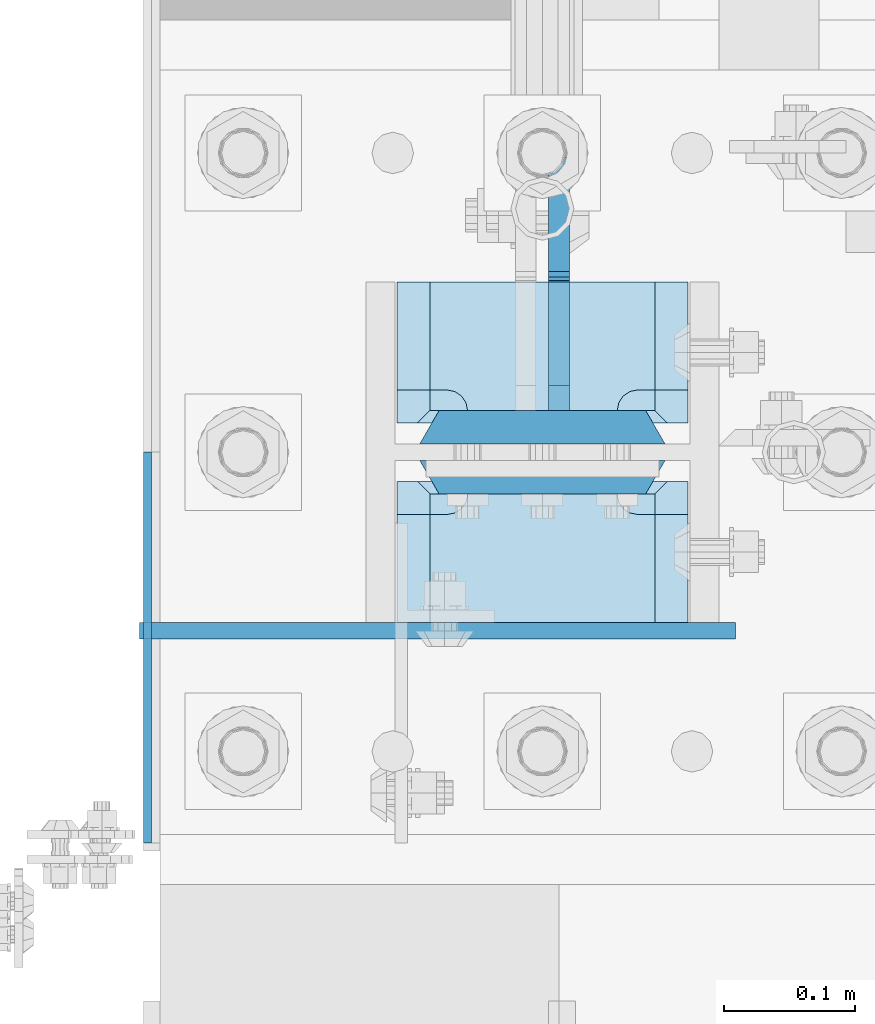
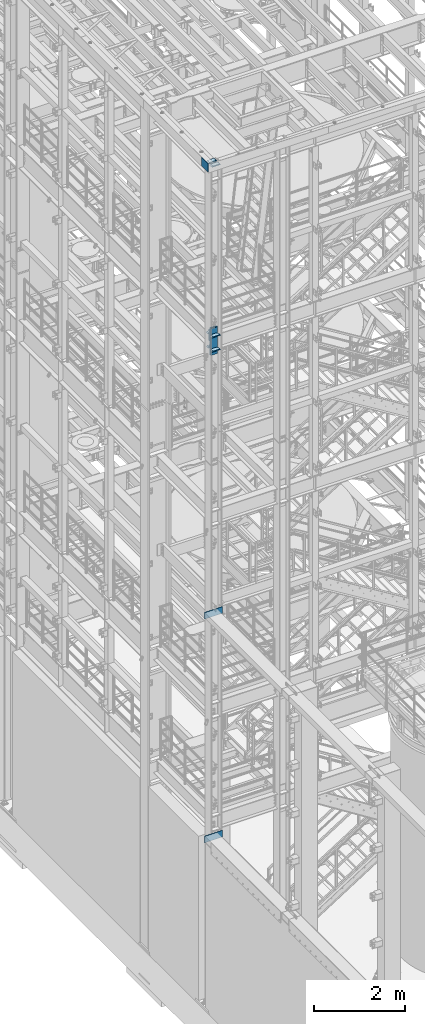
# One storey, part 1420 of 1876: 12 plates, 4 elements without a shape of their own.
"""IFC2X3 building model written with IfcOpenShell, lengths in millimetres."""

from ifc_helpers import new_model, si_unit, frame, origin_with_axes, place, context, subcontext, project, spatial, faceted_brep, material, type_object, element, aggregate, save


model = new_model("IFC2X3")

# Units and contexts
model_context = context("Model", 3, precision=1e-05, world=origin_with_axes())
body_context = subcontext(model_context, "Body", "Model", "MODEL_VIEW")
ifc_project = project(units=[si_unit("LENGTHUNIT", "METRE", prefix="MILLI"), si_unit("AREAUNIT", "SQUARE_METRE"), si_unit("VOLUMEUNIT", "CUBIC_METRE"), si_unit("MASSUNIT", "GRAM", prefix="KILO"), si_unit("TIMEUNIT", "SECOND"), si_unit("PLANEANGLEUNIT", "RADIAN"), si_unit("SOLIDANGLEUNIT", "STERADIAN"), si_unit("THERMODYNAMICTEMPERATUREUNIT", "DEGREE_CELSIUS"), si_unit("LUMINOUSINTENSITYUNIT", "LUMEN")], contexts=[model_context])

# Site, building, storey
site_placement = place(None, origin_with_axes())
site = spatial("IfcSite", under=ifc_project, at=site_placement, CompositionType="ELEMENT")
building_placement = place(site_placement, origin_with_axes())
building = spatial("IfcBuilding", under=site, at=building_placement, Name="Undefined", CompositionType="ELEMENT")
storey_placement = place(building_placement, origin_with_axes())
storey = spatial("IfcBuildingStorey", under=building, at=storey_placement, Name="Undefined", CompositionType="ELEMENT", Elevation=0.0)

# Assembly, plate
assembly_1_placement = place(storey_placement, origin_with_axes())
assembly_1 = element("IfcElementAssembly", 1, at=assembly_1_placement, inside=storey, Name="BEAM", AssemblyPlace="NOTDEFINED", PredefinedType="RIGID_FRAME")
ifc_material_1 = material(Name="STEEL/A36")
plate_type_1 = type_object("IfcPlateType", PredefinedType="NOTDEFINED")
plate_1_placement = place(assembly_1_placement, frame((-307.975000000001, -7248.525, 10680.7), z_axis=(0.0, 0.0, -1.0), x_axis=(1.0, 0.0, 0.0)))
plate_1 = element("IfcPlate", 2, at=plate_1_placement, type_object=plate_type_1, material=ifc_material_1, Name="PLATE", context=body_context, shape_type="Brep", body=[
    faceted_brep([(0.0, -6.35000000000036, 0.0), (1.70530256582424e-13, -6.35000000000036, 177.799987792969), (1.70530256582424e-13, 6.35000000000036, 177.799987792969), (0.0, 6.35000000000036, 0.0), (455.612487792969, -6.35000000000036, 177.799987792969), (455.612487792969, 6.35000000000036, 177.799987792969), (455.612487792969, -6.35000000000036, 0.0), (455.612487792969, 6.35000000000036, 0.0)], [[[0, 1, 2, 3]], [[1, 4, 5, 2]], [[4, 6, 7, 5]], [[6, 0, 3, 7]], [[5, 7, 3, 2]], [[6, 4, 1, 0]]]),
])
aggregate(assembly_1, [plate_1])

assembly_2_placement = place(storey_placement, origin_with_axes())
assembly_2 = element("IfcElementAssembly", 3, at=assembly_2_placement, inside=storey, Name="BEAM", AssemblyPlace="NOTDEFINED", PredefinedType="RIGID_FRAME")
plate_2_placement = place(assembly_2_placement, frame((-307.975, -7248.525, 4686.3), z_axis=(0.0, 0.0, -1.0), x_axis=(1.0, 0.0, 0.0)))
plate_2 = element("IfcPlate", 4, at=plate_2_placement, type_object=plate_type_1, material=ifc_material_1, Name="PLATE", context=body_context, shape_type="Brep", body=[
    faceted_brep([(0.0, -6.35000000000036, 0.0), (1.70530256582424e-13, -6.35000000000036, 177.799987792969), (1.70530256582424e-13, 6.35000000000036, 177.799987792969), (0.0, 6.35000000000036, 0.0), (455.612487792969, -6.35000000000036, 177.799987792969), (455.612487792969, 6.35000000000036, 177.799987792969), (455.612487792969, -6.35000000000036, 0.0), (455.612487792969, 6.35000000000036, 0.0)], [[[0, 1, 2, 3]], [[1, 4, 5, 2]], [[4, 6, 7, 5]], [[6, 0, 3, 7]], [[5, 7, 3, 2]], [[6, 4, 1, 0]]]),
])
aggregate(assembly_2, [plate_2])

# Assembly, plates
assembly_3_placement = place(storey_placement, origin_with_axes())
assembly_3 = element("IfcElementAssembly", 5, at=assembly_3_placement, inside=storey, Name="COLUMN", AssemblyPlace="NOTDEFINED", PredefinedType="RIGID_FRAME")
ifc_material_2 = material(Name="STEEL/A572-50")
plate_type_2 = type_object("IfcPlateType", PredefinedType="NOTDEFINED")
plate_3_placement = place(assembly_3_placement, frame((111.125, -7143.75, 17586.325012207), z_axis=(-1.0, 0.0, 0.0), x_axis=(0.0, -1.0, 0.0)))
plate_3 = element("IfcPlate", 6, at=plate_3_placement, type_object=plate_type_2, material=ifc_material_2, Name="PLATE", context=body_context, shape_type="Brep", body=[
    faceted_brep([(98.4250030517578, -12.7000000000007, 222.25), (98.4250030517578, 12.7000000000007, 197.150000002177), (15.875, 12.7000000000007, 197.150000002177), (15.875, -12.7000000000007, 222.25), (14.6665875786157, -12.7000000000007, 178.074902037082), (15.875, -12.7000000000007, 184.150001525879), (15.875, 12.7000000000007, 184.150001525879), (14.6665875786157, 12.7000000000007, 178.074902037082), (11.2253201513358, -12.7000000000007, 172.924681374541), (11.2253201513358, 12.7000000000007, 172.924681374541), (6.07509948879488, -12.7000000000007, 169.483413947261), (6.07509948879488, 12.7000000000007, 169.483413947261), (0.0, -12.7000000000007, 168.275001525879), (0.0, 12.7000000000007, 168.275001525879), (0.0, -12.7000000000007, 53.9749984741211), (0.0, 12.7000000000007, 53.9749984741211), (6.07509948879579, -12.7000000000007, 52.7665860527377), (6.07509948879579, 12.7000000000007, 52.7665860527377), (11.2253201513367, -12.7000000000007, 49.3253186254576), (11.2253201513367, 12.7000000000007, 49.3253186254576), (14.6665875786166, -12.7000000000007, 44.1750979629169), (14.6665875786166, 12.7000000000007, 44.1750979629169), (15.875, -12.7000000000007, 38.0999984741211), (15.875, 12.7000000000007, 38.0999984741211), (15.875, 12.7000000000007, 25.0999999978233), (15.875, -12.7000000000007, 0.0), (98.4250030517578, 12.7000000000007, 25.0999999978233), (98.4250030517578, -12.7000000000007, 0.0)], [[[0, 1, 2, 3]], [[4, 5, 6, 7]], [[8, 4, 7, 9]], [[10, 8, 9, 11]], [[12, 10, 11, 13]], [[14, 12, 13, 15]], [[16, 14, 15, 17]], [[18, 16, 17, 19]], [[20, 18, 19, 21]], [[22, 20, 21, 23]], [[22, 23, 24, 25]], [[26, 27, 25, 24]], [[5, 4, 8, 10, 12, 14, 16, 18, 20, 22, 25, 27, 0, 3]], [[6, 5, 3, 2]], [[26, 24, 23, 21, 19, 17, 15, 13, 11, 9, 7, 6, 2, 1]], [[27, 26, 1, 0]]]),
])
plate_4_placement = place(assembly_3_placement, frame((111.125, -7143.75, 17970.5), z_axis=(-1.0, 0.0, 0.0), x_axis=(0.0, -1.0, 0.0)))
plate_4 = element("IfcPlate", 7, at=plate_4_placement, type_object=plate_type_2, material=ifc_material_2, Name="PLATE", context=body_context, shape_type="Brep", body=[
    faceted_brep([(98.4250030517578, -12.7000000000007, 222.25), (98.4250030517578, 12.7000000000007, 197.150000002177), (15.875, 12.7000000000007, 197.150000002177), (15.875, -12.7000000000007, 222.25), (14.6665875786157, -12.7000000000007, 178.074902037082), (15.875, -12.7000000000007, 184.150001525879), (15.875, 12.7000000000007, 184.150001525879), (14.6665875786157, 12.7000000000007, 178.074902037082), (11.2253201513358, -12.7000000000007, 172.924681374541), (11.2253201513358, 12.7000000000007, 172.924681374541), (6.07509948879488, -12.7000000000007, 169.483413947261), (6.07509948879488, 12.7000000000007, 169.483413947261), (0.0, -12.7000000000007, 168.275001525879), (0.0, 12.7000000000007, 168.275001525879), (0.0, -12.7000000000007, 53.9749984741211), (0.0, 12.7000000000007, 53.9749984741211), (6.07509948879579, -12.7000000000007, 52.7665860527377), (6.07509948879579, 12.7000000000007, 52.7665860527377), (11.2253201513367, -12.7000000000007, 49.3253186254576), (11.2253201513367, 12.7000000000007, 49.3253186254576), (14.6665875786166, -12.7000000000007, 44.1750979629169), (14.6665875786166, 12.7000000000007, 44.1750979629169), (15.875, -12.7000000000007, 38.0999984741211), (15.875, 12.7000000000007, 38.0999984741211), (15.875, 12.7000000000007, 25.0999999978233), (15.875, -12.7000000000007, 0.0), (98.4250030517578, 12.7000000000007, 25.0999999978233), (98.4250030517578, -12.7000000000007, 0.0)], [[[0, 1, 2, 3]], [[4, 5, 6, 7]], [[8, 4, 7, 9]], [[10, 8, 9, 11]], [[12, 10, 11, 13]], [[14, 12, 13, 15]], [[16, 14, 15, 17]], [[18, 16, 17, 19]], [[20, 18, 19, 21]], [[22, 20, 21, 23]], [[22, 23, 24, 25]], [[26, 27, 25, 24]], [[5, 4, 8, 10, 12, 14, 16, 18, 20, 22, 25, 27, 0, 3]], [[6, 5, 3, 2]], [[26, 24, 23, 21, 19, 17, 15, 13, 11, 9, 7, 6, 2, 1]], [[27, 26, 1, 0]]]),
])
plate_5_placement = place(assembly_3_placement, frame((111.125, -6981.825, 17586.325012207), z_axis=(-1.0, 0.0, 0.0), x_axis=(0.0, -1.0, 0.0)))
plate_5 = element("IfcPlate", 8, at=plate_5_placement, type_object=plate_type_2, material=ifc_material_2, Name="PLATE", context=body_context, shape_type="Brep", body=[
    faceted_brep([(82.5500030517578, -12.7000000000007, 222.25), (82.5500030517578, 12.7000000000007, 197.150000002177), (0.0, 12.7000000000007, 197.150000002177), (0.0, -12.7000000000007, 222.25), (82.5500030517578, 12.7000000000007, 25.0999999978233), (82.5500030517578, -12.7000000000007, 0.0), (0.0, -12.6999999999998, 0.0), (0.0, 12.7000000000007, 25.0999999978233), (82.5500030517578, 12.7000000000007, 38.0999984741211), (82.5500030517578, -12.7000000000007, 38.0999984741211), (83.7584154731412, -12.7000000000007, 44.1750979629169), (83.7584154731412, 12.7000000000007, 44.1750979629169), (87.1996829004211, -12.7000000000007, 49.3253186254576), (87.1996829004211, 12.7000000000007, 49.3253186254576), (92.349903562962, -12.7000000000007, 52.7665860527377), (92.349903562962, 12.7000000000007, 52.7665860527377), (98.4250030517578, -12.7000000000007, 53.9749984741211), (98.4250030517578, 12.7000000000007, 53.9749984741211), (98.4250030517578, -12.7000000000007, 168.275001525879), (98.4250030517578, 12.7000000000007, 168.275001525879), (92.349903562962, -12.7000000000007, 169.483413947262), (92.349903562962, 12.7000000000007, 169.483413947262), (87.1996829004211, -12.7000000000007, 172.924681374543), (87.1996829004211, 12.7000000000007, 172.924681374543), (83.7584154731412, -12.7000000000007, 178.074902037083), (83.7584154731412, 12.7000000000007, 178.074902037083), (82.5500030517578, -12.7000000000007, 184.150001525879), (82.5500030517578, 12.7000000000007, 184.150001525879)], [[[0, 1, 2, 3]], [[4, 5, 6, 7]], [[8, 9, 5, 4]], [[10, 9, 8, 11]], [[12, 10, 11, 13]], [[14, 12, 13, 15]], [[16, 14, 15, 17]], [[18, 16, 17, 19]], [[20, 18, 19, 21]], [[22, 20, 21, 23]], [[24, 22, 23, 25]], [[26, 24, 25, 27]], [[6, 5, 9, 10, 12, 14, 16, 18, 20, 22, 24, 26, 0, 3]], [[7, 6, 3, 2]], [[27, 25, 23, 21, 19, 17, 15, 13, 11, 8, 4, 7, 2, 1]], [[26, 27, 1, 0]]]),
])
plate_6_placement = place(assembly_3_placement, frame((111.125, -6981.825, 17970.5), z_axis=(-1.0, 0.0, 0.0), x_axis=(0.0, -1.0, 0.0)))
plate_6 = element("IfcPlate", 9, at=plate_6_placement, type_object=plate_type_2, material=ifc_material_2, Name="PLATE", context=body_context, shape_type="Brep", body=[
    faceted_brep([(82.5500030517578, -12.7000000000007, 222.25), (82.5500030517578, 12.7000000000007, 197.150000002177), (0.0, 12.7000000000007, 197.150000002177), (0.0, -12.7000000000007, 222.25), (82.5500030517578, 12.7000000000007, 25.0999999978233), (82.5500030517578, -12.7000000000007, 0.0), (0.0, -12.6999999999998, 0.0), (0.0, 12.7000000000007, 25.0999999978233), (82.5500030517578, 12.7000000000007, 38.0999984741211), (82.5500030517578, -12.7000000000007, 38.0999984741211), (83.7584154731412, -12.7000000000007, 44.1750979629169), (83.7584154731412, 12.7000000000007, 44.1750979629169), (87.1996829004211, -12.7000000000007, 49.3253186254576), (87.1996829004211, 12.7000000000007, 49.3253186254576), (92.349903562962, -12.7000000000007, 52.7665860527377), (92.349903562962, 12.7000000000007, 52.7665860527377), (98.4250030517578, -12.7000000000007, 53.9749984741211), (98.4250030517578, 12.7000000000007, 53.9749984741211), (98.4250030517578, -12.7000000000007, 168.275001525879), (98.4250030517578, 12.7000000000007, 168.275001525879), (92.349903562962, -12.7000000000007, 169.483413947262), (92.349903562962, 12.7000000000007, 169.483413947262), (87.1996829004211, -12.7000000000007, 172.924681374543), (87.1996829004211, 12.7000000000007, 172.924681374543), (83.7584154731412, -12.7000000000007, 178.074902037083), (83.7584154731412, 12.7000000000007, 178.074902037083), (82.5500030517578, -12.7000000000007, 184.150001525879), (82.5500030517578, 12.7000000000007, 184.150001525879)], [[[0, 1, 2, 3]], [[4, 5, 6, 7]], [[8, 9, 5, 4]], [[10, 9, 8, 11]], [[12, 10, 11, 13]], [[14, 12, 13, 15]], [[16, 14, 15, 17]], [[18, 16, 17, 19]], [[20, 18, 19, 21]], [[22, 20, 21, 23]], [[24, 22, 23, 25]], [[26, 24, 25, 27]], [[6, 5, 9, 10, 12, 14, 16, 18, 20, 22, 24, 26, 0, 3]], [[7, 6, 3, 2]], [[27, 25, 23, 21, 19, 17, 15, 13, 11, 8, 4, 7, 2, 1]], [[26, 27, 1, 0]]]),
])
ifc_material_3 = material(Name="STEEL/A572-GR.50")
plate_type_3 = type_object("IfcPlateType", PredefinedType="NOTDEFINED")
plate_7_placement = place(assembly_3_placement, frame((-93.6625, -7131.05, 18135.6), z_axis=(1.0, 0.0, 0.0), x_axis=(0.0, 0.0, -1.0)))
plate_7 = element("IfcPlate", 10, at=plate_7_placement, type_object=plate_type_3, material=ifc_material_3, Name="PLATE", context=body_context, shape_type="Brep", body=[
    faceted_brep([(0.0, -12.6999999999998, 172.660303166218), (714.375, -12.6999999999998, 172.660303166232), (714.375, 12.6999999999998, 187.324996948242), (0.0, 12.6999999999998, 187.324996948242), (714.375, -12.6999999999998, 14.6646968337647), (714.375, 12.6999999999998, 0.0), (0.0, 12.6999999999998, 0.0), (0.0, -12.6999999999998, 14.6646968337648)], [[[0, 1, 2, 3]], [[2, 1, 4, 5]], [[3, 2, 5, 6]], [[0, 3, 6, 7]], [[1, 0, 7, 4]], [[6, 5, 4, 7]]]),
])
plate_8_placement = place(assembly_3_placement, frame((-93.6625, -7092.95, 18135.6), z_axis=(1.0, 0.0, 0.0), x_axis=(0.0, 0.0, -1.0)))
plate_8 = element("IfcPlate", 11, at=plate_8_placement, type_object=plate_type_3, material=ifc_material_3, Name="PLATE", context=body_context, shape_type="Brep", body=[
    faceted_brep([(0.0, 12.6999999999998, 172.66030316161), (0.0, -12.6999999999998, 187.324996948242), (714.375, -12.6999999999998, 187.324996948242), (714.375, 12.6999999999998, 172.660303161603), (714.375, 12.6999999999998, 14.6646968384017), (0.0, 12.6999999999998, 14.6646968383725), (0.0, -12.6999999999998, 0.0), (714.375, -12.6999999999998, 0.0)], [[[0, 1, 2, 3]], [[0, 3, 4, 5]], [[1, 0, 5, 6]], [[2, 1, 6, 7]], [[3, 2, 7, 4]], [[6, 5, 4, 7]]]),
])
plate_type_4 = type_object("IfcPlateType", PredefinedType="NOTDEFINED")
plate_9_placement = place(assembly_3_placement, frame((111.124999999997, -7118.35, 22542.5), z_axis=(-1.0, 0.0, 0.0), x_axis=(0.0, -1.0, 0.0)))
plate_9 = element("IfcPlate", 12, at=plate_9_placement, type_object=plate_type_4, material=ifc_material_2, Name="PLATE", context=body_context, shape_type="Brep", body=[
    faceted_brep([(123.824996948242, -12.5499999989115, 222.40000000109), (123.824996948242, 12.7000000000007, 197.15000000218), (25.4000000000024, 12.7000000000007, 197.15000000218), (15.875, 3.17499999999563, 206.675000002184), (15.875, -12.7000000000007, 222.25), (14.6665875786157, -12.7000000000007, 178.074902037082), (15.875, -12.7000000000007, 184.150001525879), (15.875, 3.17499999999563, 184.150001525879), (14.6665875786157, 1.96658757861223, 178.074902037082), (11.2253201513358, -12.7000000000007, 172.924681374541), (11.2253201513358, -1.47467984866671, 172.924681374541), (6.07509948879488, -12.7000000000007, 169.483413947261), (6.07509948879488, -6.62490051120767, 169.483413947261), (0.0, -12.7000000000007, 168.275001525879), (6.07509948879579, -12.7000000000007, 52.7665860527377), (0.0, -12.7000000000007, 53.9749984741211), (6.07509948879579, -6.62490051120767, 52.7665860527377), (11.2253201513367, -12.7000000000007, 49.3253186254576), (11.2253201513367, -1.47467984866671, 49.3253186254576), (14.6665875786166, -12.7000000000007, 44.1750979629169), (14.6665875786166, 1.96658757861223, 44.1750979629169), (15.875, -12.7000000000007, 38.0999984741211), (15.875, 3.17499999999563, 38.0999984741211), (15.875, 3.17499999999563, 15.6499999983591), (15.875, -12.7000000000007, 0.0), (123.824996948242, 12.7000000000007, 25.1749999983624), (123.824996948242, -12.7000000000007, 0.0), (25.4000000000024, 12.7000000000007, 25.1749999983624)], [[[0, 1, 2, 3, 4]], [[5, 6, 7, 8]], [[9, 5, 8, 10]], [[11, 9, 10, 12]], [[11, 12, 13]], [[14, 15, 16]], [[17, 14, 16, 18]], [[19, 17, 18, 20]], [[21, 19, 20, 22]], [[21, 22, 23, 24]], [[25, 26, 24, 23, 27]], [[6, 5, 9, 11, 13, 15, 14, 17, 19, 21, 24, 26, 0, 4]], [[7, 6, 4, 3]], [[27, 23, 22, 20, 18, 16, 15, 13, 12, 10, 8, 7, 3, 2]], [[25, 27, 2, 1]], [[26, 25, 1, 0]]]),
])
plate_10_placement = place(assembly_3_placement, frame((111.124999999997, -6981.825, 22542.5), z_axis=(-1.0, 0.0, 0.0), x_axis=(0.0, -1.0, 0.0)))
plate_10 = element("IfcPlate", 13, at=plate_10_placement, type_object=plate_type_4, material=ifc_material_2, Name="PLATE", context=body_context, shape_type="Brep", body=[
    faceted_brep([(107.950004577637, -12.7000000000007, 222.25), (107.950004577637, 3.17499829605367, 206.675001706127), (98.4250030517578, 12.7000000000007, 197.150000002177), (0.0, 12.7000000000007, 197.150000002177), (0.0, -12.7000000000007, 222.25), (107.950004577637, 3.17499829605367, 15.5749982938728), (107.950004577637, -12.7000000000007, 0.0), (0.0, -12.6999999999998, 0.0), (0.0, 12.7000000000007, 25.0999999978233), (98.4250030517578, 12.7000000000007, 25.0999999978233), (107.950004577637, 3.17499829605367, 38.0999984741211), (107.950004577637, -12.7000000000007, 38.0999984741211), (109.15841699902, -12.7000000000007, 44.1750979629169), (109.15841699902, 1.96658565592224, 44.1750979629169), (112.5996844263, -12.7000000000007, 49.3253186254576), (112.5996844263, -1.47468239429145, 49.3253186254576), (117.749905088841, -12.7000000000007, 52.7665860527377), (117.749905088841, -6.62490398912269, 52.7665860527377), (123.825004577637, -12.7000000000007, 53.9749984741211), (117.749905088841, -12.7000000000007, 169.483413947262), (123.825004577637, -12.7000000000007, 168.275001525879), (117.749905088841, -6.62490398912269, 169.483413947262), (112.5996844263, -12.7000000000007, 172.924681374543), (112.5996844263, -1.47468239429145, 172.924681374543), (109.15841699902, -12.7000000000007, 178.074902037083), (109.15841699902, 1.96658565592588, 178.074902037083), (107.950004577637, -12.7000000000007, 184.150001525879), (107.950004577637, 3.17499829605367, 184.150001525879)], [[[0, 1, 2, 3, 4]], [[5, 6, 7, 8, 9]], [[10, 11, 6, 5]], [[12, 11, 10, 13]], [[14, 12, 13, 15]], [[16, 14, 15, 17]], [[16, 17, 18]], [[19, 20, 21]], [[22, 19, 21, 23]], [[24, 22, 23, 25]], [[26, 24, 25, 27]], [[7, 6, 11, 12, 14, 16, 18, 20, 19, 22, 24, 26, 0, 4]], [[8, 7, 4, 3]], [[9, 8, 3, 2]], [[27, 25, 23, 21, 20, 18, 17, 15, 13, 10, 5, 9, 2, 1]], [[26, 27, 1, 0]]]),
])

# Assembly, plate
assembly_4_placement = place(storey_placement, origin_with_axes())
assembly_4 = element("IfcElementAssembly", 14, at=assembly_4_placement, inside=storey, Name="BENT PLATE", AssemblyPlace="NOTDEFINED", PredefinedType="RIGID_FRAME")
plate_type_5 = type_object("IfcPlateType", PredefinedType="NOTDEFINED")
plate_11_placement = place(assembly_4_placement, frame((-301.624713179216, -7410.45028679216, 22561.5500191472), z_axis=(-1.22699999991482e-06, 7.19900000422058e-06, 0.999999999973334), x_axis=(0.0, 0.999999999968684, -7.91400000071008e-06)))
plate_11 = element("IfcPlate", 15, at=plate_11_placement, type_object=plate_type_5, material=ifc_material_1, Name="PLATE", context=body_context, shape_type="Brep", body=[
    faceted_brep([(-0.000137146941597166, -3.1750000000003, 19.0499992365876), (-0.00168289586326864, -3.17500000000371, 233.757781982702), (-0.00168289586417814, 3.17499999999637, 233.757781982706), (-0.000137146943416155, 3.17499999999978, 19.0499992365949), (298.448608398525, -3.17500000000371, 233.759948730807), (298.448608398524, 3.17499999999637, 233.759948730811), (298.44995117201, -3.17499999999745, -1.81898940354586e-11), (298.449951172007, 3.17499999999836, -1.09139364212751e-11), (19.0499992370706, -3.17499999999745, -3.63797880709171e-12), (19.0499992370678, 3.17499999999836, 3.63797880709171e-12)], [[[0, 1, 2, 3]], [[1, 4, 5, 2]], [[4, 6, 7, 5]], [[6, 8, 9, 7]], [[8, 0, 3, 9]], [[5, 7, 9, 3, 2]], [[8, 6, 4, 1, 0]]]),
])
aggregate(assembly_4, [plate_11])

# Plate
plate_type_6 = type_object("IfcPlateType", PredefinedType="NOTDEFINED")
plate_12_placement = place(assembly_3_placement, frame((12.6995000839233, -7080.2495, 17957.8), z_axis=(0.0, 1.0, 0.0), x_axis=(0.0, 0.0, -1.0)))
plate_12 = element("IfcPlate", 16, at=plate_12_placement, type_object=plate_type_6, material=ifc_material_2, Name="PLATE", context=body_context, shape_type="Brep", body=[
    faceted_brep([(317.499987030027, -7.9375, 193.675002687786), (317.499987030027, -7.9375, 111.124999809264), (317.499987030027, 7.9375, 111.124999809264), (317.499987030027, 7.9375, 193.675003051758), (318.466716952618, -7.9375, 106.264920291219), (318.466716952618, 7.9375, 106.264920291219), (321.219730853096, -7.9375, 102.144743823065), (321.219730853096, 7.9375, 102.144743823065), (325.339907321249, -7.9375, 99.3917299225868), (325.339907321249, 7.9375, 99.3917299225868), (330.199986839292, -7.9375, 98.4249999999993), (330.199986839292, 7.9375, 98.4249999999993), (358.774999999998, -7.9375, 98.4249999999993), (358.774993896484, 7.9375, 98.4249999999993), (12.7000000839216, -7.9375, 193.674999999999), (12.7000000839216, 7.9375, 193.675003051758), (12.7000000839216, 7.9375, 111.124999809264), (12.7000000839216, -7.9375, 111.124999809264), (11.7332701613341, 7.9375, 106.264920291219), (11.7332701613341, -7.9375, 106.264920291219), (8.98025626085655, 7.9375, 102.144743823065), (8.98025626085655, -7.9375, 102.144743823065), (4.86007979270289, 7.9375, 99.3917299225868), (4.86007979270289, -7.9375, 99.3917299225868), (0.0, 7.9375, 98.4249999999993), (0.0, -7.9375, 98.4249999999993), (0.0, 7.9375, 19.0499992370605), (0.0, -7.9375, 19.0499992370605), (19.0499992370605, -7.9375, 0.0), (19.0499992370605, 7.9375, 0.0), (339.724994659424, -7.9375, 0.0), (339.724994659424, 7.9375, 0.0), (358.774993896484, -7.9375, 19.0499992370605), (358.774993896484, 7.9375, 19.0499992370605)], [[[0, 1, 2, 3]], [[4, 5, 2, 1]], [[6, 7, 5, 4]], [[8, 9, 7, 6]], [[10, 11, 9, 8]], [[12, 13, 11, 10]], [[14, 15, 16, 17]], [[17, 16, 18, 19]], [[19, 18, 20, 21]], [[21, 20, 22, 23]], [[23, 22, 24, 25]], [[26, 27, 25, 24]], [[28, 27, 26, 29]], [[30, 28, 29, 31]], [[32, 30, 31, 33]], [[8, 6, 4, 1, 0, 14, 17, 19, 21, 23, 25, 27, 28, 30, 32, 12, 10]], [[15, 14, 0, 3]], [[33, 31, 29, 26, 24, 22, 20, 18, 16, 15, 3, 2, 5, 7, 9, 11, 13]], [[32, 33, 13, 12]]]),
])

aggregate(assembly_3, [plate_9, plate_10, plate_3, plate_4, plate_5, plate_6, plate_7, plate_8, plate_12])

save(model, "model.ifc")
